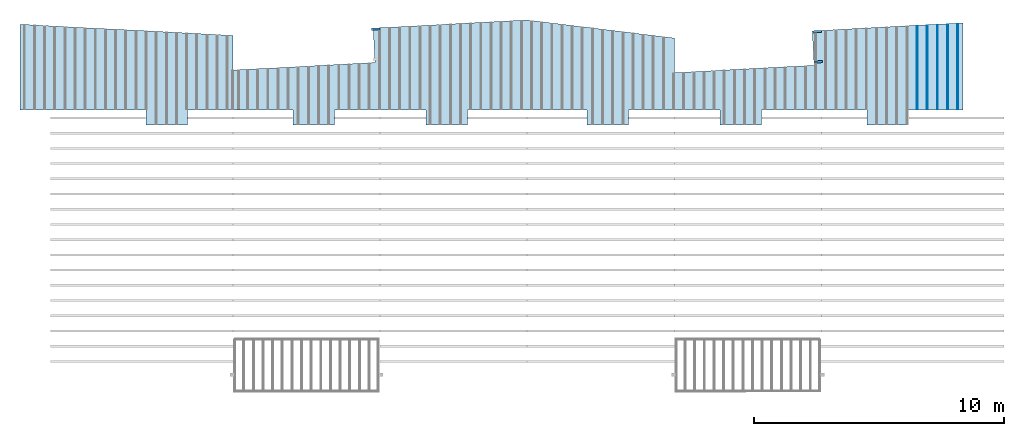
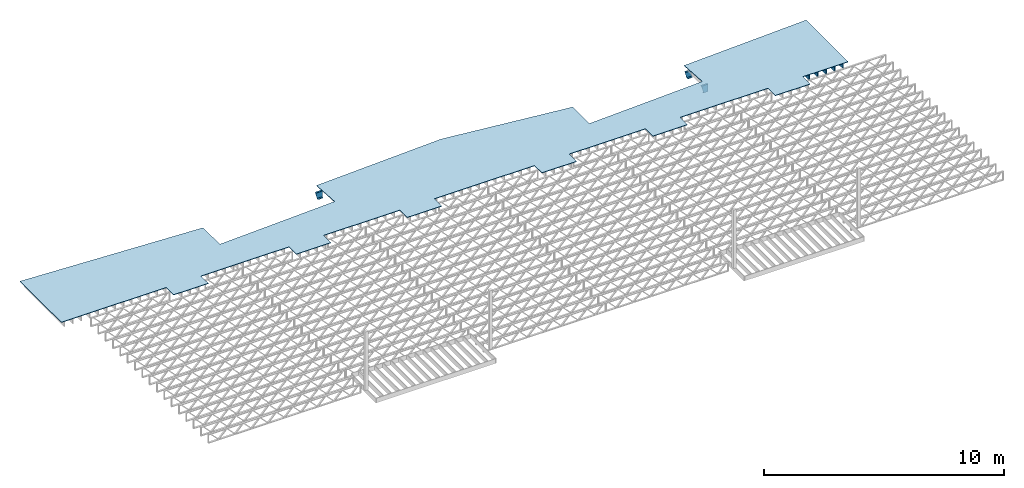
# One storey, part 12 of 12: 8 beams, 1 slab, 1 element without a shape of its own.
"""IFC4 building model written with IfcOpenShell, lengths in feet."""

import ifcopenshell
import ifcopenshell.guid

model = None  # the IFC model being written
_history = None  # IfcOwnerHistory: only IFC2X3 demands one
_inside = {}  # id of a spatial element -> (the spatial element, [elements in it])
_under = {}  # id of a project, library or spatial element -> (it, [spatial elements below it])
_declared = {}  # id of a project -> (the project, [libraries it declares])
_typed = {}  # id of a type object -> (the type object, [elements of that type])
_made_of = {}  # id of a material, layer set ... -> (it, [elements and type objects made of it])


def new_model(schema):
    """Start an empty IFC model of exactly this schema.

    Asked for "IFC4X3", IfcOpenShell would pick the latest addendum, in which some entities
    have other attributes; the version numbers below select the first issue.
    IFC2X3 requires an IfcOwnerHistory on every rooted entity: one is made here for all.
    """
    global model, _history
    if schema == "IFC4X3":
        model = ifcopenshell.file(schema_version=(4, 3, 0, 0))
    else:
        model = ifcopenshell.file(schema=schema)
    _inside.clear()
    _under.clear()
    _declared.clear()
    _typed.clear()
    _made_of.clear()
    _history = None
    if model.schema == "IFC2X3":
        org = make("IfcOrganization", Name="unknown")
        user = make(
            "IfcPersonAndOrganization",
            ThePerson=make("IfcPerson", FamilyName="unknown"),
            TheOrganization=org,
        )
        app = make(
            "IfcApplication",
            ApplicationDeveloper=org,
            Version="unknown",
            ApplicationFullName="unknown",
            ApplicationIdentifier="unknown",
        )
        _history = make(
            "IfcOwnerHistory",
            OwningUser=user,
            OwningApplication=app,
            ChangeAction="ADDED",
            CreationDate=0,
        )
    return model


def make(cls, **values):
    """One entity of the class cls with the attributes given. An attribute that is None is left unset."""
    return model.create_entity(
        cls, **{name: value for name, value in values.items() if value is not None}
    )


def entity(cls, *values):
    """Any entity or typed value of the class cls, its attributes in the order of the schema. None: left unset."""
    e = model.create_entity(cls)
    for i, value in enumerate(values):
        if value is not None:
            e[i] = value
    return e


def rooted(cls, **values):
    """An entity with a GlobalId (a new one), such as an element, a storey or a relation."""
    return make(cls, GlobalId=ifcopenshell.guid.new(), OwnerHistory=_history, **values)


def si_unit(unit_type, name, prefix=None):
    """IfcSIUnit, for example si_unit("LENGTHUNIT", "METRE", prefix="MILLI")."""
    return make("IfcSIUnit", UnitType=unit_type, Prefix=prefix, Name=name)


def converted_unit(unit_type, name, factor, base, dimensions=None, offset=None):
    """IfcConversionBasedUnit, such as the inch: factor (a typed value) times the base unit."""
    return make(
        "IfcConversionBasedUnit"
        if offset is None
        else "IfcConversionBasedUnitWithOffset",
        ConversionOffset=offset,
        Dimensions=None
        if dimensions is None
        else entity("IfcDimensionalExponents", *dimensions),
        UnitType=unit_type,
        Name=name,
        ConversionFactor=make(
            "IfcMeasureWithUnit", ValueComponent=factor, UnitComponent=base
        ),
    )


def derived_unit(unit_type, elements):
    """IfcDerivedUnit: a product of units, each with its exponent."""
    return make(
        "IfcDerivedUnit",
        Elements=[
            make("IfcDerivedUnitElement", Unit=unit, Exponent=power)
            for unit, power in elements
        ],
        UnitType=unit_type,
    )


def assignment(units):
    """IfcUnitAssignment: the units of a project."""
    return None if units is None else make("IfcUnitAssignment", Units=units)


def point(xyz):
    """IfcCartesianPoint."""
    return None if xyz is None else make("IfcCartesianPoint", Coordinates=xyz)


def direction(xyz):
    """IfcDirection."""
    return None if xyz is None else make("IfcDirection", DirectionRatios=xyz)


def frame(location, z_axis=None, x_axis=None):
    """IfcAxis2Placement3D, a coordinate frame: its origin and axes. An axis left out is left unset."""
    return make(
        "IfcAxis2Placement3D",
        Location=point(location),
        Axis=direction(z_axis),
        RefDirection=direction(x_axis),
    )


def frame_2d(location, x_axis=None):
    """IfcAxis2Placement2D, a coordinate frame in the plane: its origin and x axis."""
    return make(
        "IfcAxis2Placement2D", Location=point(location), RefDirection=direction(x_axis)
    )


def origin():
    """The frame at (0, 0, 0) with its axes left unset."""
    return frame((0.0, 0.0, 0.0))


def origin_2d_with_axis():
    """The frame at (0, 0) in the plane with the x axis (1, 0) written out."""
    return frame_2d((0.0, 0.0), x_axis=(1.0, 0.0))


def place(relative_to, where):
    """IfcLocalPlacement: puts the frame where relative to a parent placement (None: the world)."""
    return make(
        "IfcLocalPlacement", PlacementRelTo=relative_to, RelativePlacement=where
    )


def context(
    kind, dimensions, precision=None, world=None, true_north=None, identifier=None
):
    """IfcGeometricRepresentationContext, for example the 3D "Model" context."""
    return make(
        "IfcGeometricRepresentationContext",
        ContextIdentifier=identifier,
        ContextType=kind,
        CoordinateSpaceDimension=dimensions,
        Precision=precision,
        WorldCoordinateSystem=world,
        TrueNorth=true_north,
    )


def subcontext(parent, identifier, kind, view, scale=None):
    """IfcGeometricRepresentationSubContext, for example "Body" below "Model"."""
    return make(
        "IfcGeometricRepresentationSubContext",
        ContextIdentifier=identifier,
        ContextType=kind,
        ParentContext=parent,
        TargetScale=scale,
        TargetView=view,
    )


def project(units=None, contexts=None):
    """IfcProject with its units and contexts."""
    return rooted(
        "IfcProject",
        Name="project",
        RepresentationContexts=contexts,
        UnitsInContext=assignment(units),
    )


def spatial(cls, under=None, at=None, **own):
    """A site, building, storey or space (cls), placed at a placement, below another one or the project."""
    s = rooted(cls, ObjectPlacement=at, **own)
    if under is not None:
        _under.setdefault(under.id(), (under, []))[1].append(s)
    return s


def polyline(points):
    """IfcPolyline through the points."""
    return make("IfcPolyline", Points=[point(p) for p in points])


def circle_curve(where, radius):
    """IfcCircle in the frame where."""
    return make("IfcCircle", Position=where, Radius=radius)


def parameter(value):
    """IfcParameterValue: where a trimmed curve begins or ends, as a parameter of its basis curve."""
    return model.create_entity("IfcParameterValue", value)


def trimmed(basis, trim1, trim2, sense, master):
    """IfcTrimmedCurve: the piece of a basis curve between two trims."""
    return make(
        "IfcTrimmedCurve",
        BasisCurve=basis,
        Trim1=trim1,
        Trim2=trim2,
        SenseAgreement=sense,
        MasterRepresentation=master,
    )


def segment(curve, same_sense, transition):
    """IfcCompositeCurveSegment."""
    return make(
        "IfcCompositeCurveSegment",
        Transition=transition,
        SameSense=same_sense,
        ParentCurve=curve,
    )


def composite_curve(segments, self_intersect=None):
    """IfcCompositeCurve: segments joined end to end."""
    return make("IfcCompositeCurve", Segments=segments, SelfIntersect=self_intersect)


def profile(cls, at=None, kind="AREA", **sizes):
    """A parametric profile (cls). Its sizes go by their IFC names, for example OverallWidth=200.0."""
    return make(cls, ProfileType=kind, Position=at, **sizes)


def rectangle(**sizes):
    """IfcRectangleProfileDef."""
    return profile("IfcRectangleProfileDef", **sizes)


def outline(outer, holes=None, kind="AREA"):
    """IfcArbitraryClosedProfileDef: a profile drawn as a closed curve; with holes, ...WithVoids."""
    if holes is None:
        return make("IfcArbitraryClosedProfileDef", ProfileType=kind, OuterCurve=outer)
    return make(
        "IfcArbitraryProfileDefWithVoids",
        ProfileType=kind,
        OuterCurve=outer,
        InnerCurves=holes,
    )


def extrude(swept, where, along, depth):
    """IfcExtrudedAreaSolid: the profile swept, set in the frame where, extruded along a direction by depth."""
    return make(
        "IfcExtrudedAreaSolid",
        SweptArea=swept,
        Position=where,
        ExtrudedDirection=direction(along),
        Depth=depth,
    )


def clip(a, b, op="DIFFERENCE"):
    """IfcBooleanClippingResult: the solid a cut by the half space b."""
    return make(
        "IfcBooleanClippingResult", Operator=op, FirstOperand=a, SecondOperand=b
    )


def halfspace(plane, agree):
    """IfcHalfSpaceSolid: all space on one side of the plane z = 0 of the frame plane."""
    return make(
        "IfcHalfSpaceSolid",
        BaseSurface=make("IfcPlane", Position=plane),
        AgreementFlag=agree,
    )


def shape(context_of_items, identifier, shape_type, items):
    """IfcShapeRepresentation: the items that make up one representation, for example the "Body"."""
    return make(
        "IfcShapeRepresentation",
        ContextOfItems=context_of_items,
        RepresentationIdentifier=identifier,
        RepresentationType=shape_type,
        Items=items,
    )


def source(mapping_origin, context_of_items, identifier, shape_type, items):
    """IfcRepresentationMap: a shape defined once, which mapped items show again and again."""
    return make(
        "IfcRepresentationMap",
        MappingOrigin=mapping_origin,
        MappedRepresentation=shape(context_of_items, identifier, shape_type, items),
    )


def transform(
    local_origin,
    x_axis=None,
    y_axis=None,
    z_axis=None,
    scale=None,
    scale2=None,
    scale3=None,
    uniform=True,
):
    """IfcCartesianTransformationOperator3D, or its non-uniform kind. x_axis, y_axis, z_axis: its Axis1, 2, 3."""
    if uniform:
        return make(
            "IfcCartesianTransformationOperator3D",
            Axis1=direction(x_axis),
            Axis2=direction(y_axis),
            LocalOrigin=point(local_origin),
            Scale=scale,
            Axis3=direction(z_axis),
        )
    return make(
        "IfcCartesianTransformationOperator3DnonUniform",
        Axis1=direction(x_axis),
        Axis2=direction(y_axis),
        LocalOrigin=point(local_origin),
        Scale=scale,
        Axis3=direction(z_axis),
        Scale2=scale2,
        Scale3=scale3,
    )


def mapped(mapping_source, mapping_target):
    """IfcMappedItem: shows the shape of a source again, moved by a transform."""
    return make(
        "IfcMappedItem", MappingSource=mapping_source, MappingTarget=mapping_target
    )


def material(Name=None, Category=None):
    """IfcMaterial."""
    return make("IfcMaterial", Name=Name, Category=Category)


def layer(
    of_material, thickness, ventilated=None, Name=None, Category=None, Priority=None
):
    """IfcMaterialLayer: one layer of a wall or slab, of a material (None: an air gap)."""
    return make(
        "IfcMaterialLayer",
        Material=of_material,
        LayerThickness=thickness,
        IsVentilated=ventilated,
        Name=Name,
        Category=Category,
        Priority=Priority,
    )


def layer_set(layers, Name=None):
    """IfcMaterialLayerSet."""
    return make("IfcMaterialLayerSet", MaterialLayers=layers, LayerSetName=Name)


def layer_usage(for_layer_set, set_direction, sense, offset, extent=None):
    """IfcMaterialLayerSetUsage: how a layer set lies in its element."""
    return make(
        "IfcMaterialLayerSetUsage",
        ForLayerSet=for_layer_set,
        LayerSetDirection=set_direction,
        DirectionSense=sense,
        OffsetFromReferenceLine=offset,
        ReferenceExtent=extent,
    )


def material_profile(
    of_material, cross_section, Name=None, Category=None, Priority=None
):
    """IfcMaterialProfile: a cross section and its material."""
    return make(
        "IfcMaterialProfile",
        Name=Name,
        Material=of_material,
        Profile=cross_section,
        Priority=Priority,
        Category=Category,
    )


def profile_set(profiles, Name=None, composite=None):
    """IfcMaterialProfileSet."""
    return make(
        "IfcMaterialProfileSet",
        Name=Name,
        MaterialProfiles=profiles,
        CompositeProfile=composite,
    )


def profile_usage(for_profile_set, cardinal=None, extent=None):
    """IfcMaterialProfileSetUsage: how a profile set lies along its element."""
    return make(
        "IfcMaterialProfileSetUsage",
        ForProfileSet=for_profile_set,
        CardinalPoint=cardinal,
        ReferenceExtent=extent,
    )


def made_of(thing, what):
    """Note that an element or type object is made of a material, layer set ...; save() writes the relation."""
    if what is not None:
        _made_of.setdefault(what.id(), (what, []))[1].append(thing)
    return thing


def type_object(cls, material=None, **own):
    """A type object (cls), such as IfcWallType, which elements share."""
    return made_of(rooted(cls, **own), material)


def type_shapes(of_type, sources):
    """Give a type object the sources (RepresentationMaps) that its elements show as mapped items."""
    of_type.RepresentationMaps = sources


def element(
    cls,
    number,
    at=None,
    inside=None,
    cuts=None,
    type_object=None,
    material=None,
    context=None,
    identifier="Body",
    shape_type=None,
    held_by="IfcProductDefinitionShape",
    body=None,
    shapes=None,
    **own,
):
    """One element of the class cls, such as IfcWall. Its Tag is "e" and its number.

    at: its placement. inside: the storey or other place that contains it. cuts: it is an
    opening in that element (IfcRelVoidsElement). A single representation is given by context,
    identifier, shape_type and body (its items); several are given by shapes. held_by: the class
    of the entity that holds the representations. save() writes the other relations.
    """
    e = rooted(cls, Tag="e%d" % number, ObjectPlacement=at, **own)
    if body is not None:
        shapes = [shape(context, identifier, shape_type, body)]
    if shapes is not None:
        e.Representation = make(held_by, Representations=shapes)
    if inside is not None:
        _inside.setdefault(inside.id(), (inside, []))[1].append(e)
    if cuts is not None:
        rooted(
            "IfcRelVoidsElement", RelatingBuildingElement=cuts, RelatedOpeningElement=e
        )
    if type_object is not None:
        _typed.setdefault(type_object.id(), (type_object, []))[1].append(e)
    return made_of(e, material)


def aggregate(whole, parts):
    """IfcRelAggregates: a whole, such as a stair, and the parts it consists of."""
    return rooted("IfcRelAggregates", RelatingObject=whole, RelatedObjects=parts)


def save(model, path):
    """Write the relations noted so far, then the file.

    IfcRelAggregates (storeys below a building ...), IfcRelContainedInSpatialStructure (elements
    in a storey), IfcRelDefinesByType, IfcRelAssociatesMaterial and IfcRelDeclares: one each for
    every whole, place, type object, material and project.
    """
    for whole, parts in _under.values():
        aggregate(whole, parts)
    for where, things in _inside.values():
        rooted(
            "IfcRelContainedInSpatialStructure",
            RelatedElements=things,
            RelatingStructure=where,
        )
    for kind, things in _typed.values():
        rooted("IfcRelDefinesByType", RelatedObjects=things, RelatingType=kind)
    for what, things in _made_of.values():
        rooted("IfcRelAssociatesMaterial", RelatedObjects=things, RelatingMaterial=what)
    for by, libraries in _declared.values():
        rooted("IfcRelDeclares", RelatingContext=by, RelatedDefinitions=libraries)
    model.write(path)


model = new_model("IFC4")

# Units and contexts
model_context = context("Model", 3, precision=0.0001, world=origin(), true_north=direction((6.12303176911189e-17, 1.0)))
body_context = subcontext(model_context, "Body", "Model", "MODEL_VIEW")
ifc_project = project(units=[converted_unit("LENGTHUNIT", "FOOT", entity("IfcRatioMeasure", 0.3048), si_unit("LENGTHUNIT", "METRE"), dimensions=[1, 0, 0, 0, 0, 0, 0]), converted_unit("AREAUNIT", "SQUARE FOOT", entity("IfcRatioMeasure", 0.09290304), si_unit("AREAUNIT", "SQUARE_METRE"), dimensions=[2, 0, 0, 0, 0, 0, 0]), converted_unit("VOLUMEUNIT", "CUBIC FOOT", entity("IfcRatioMeasure", 0.028316846592), si_unit("VOLUMEUNIT", "CUBIC_METRE"), dimensions=[3, 0, 0, 0, 0, 0, 0]), converted_unit("PLANEANGLEUNIT", "DEGREE", entity("IfcRatioMeasure", 0.0174532925199433), si_unit("PLANEANGLEUNIT", "RADIAN"), dimensions=[0, 0, 0, 0, 0, 0, 0]), si_unit("MASSUNIT", "GRAM", prefix="KILO"), derived_unit("MASSDENSITYUNIT", [(si_unit("MASSUNIT", "GRAM", prefix="KILO"), 1), (si_unit("LENGTHUNIT", "METRE"), -3)]), derived_unit("MOMENTOFINERTIAUNIT", [(si_unit("LENGTHUNIT", "METRE"), 4)]), si_unit("TIMEUNIT", "SECOND"), si_unit("FREQUENCYUNIT", "HERTZ"), si_unit("THERMODYNAMICTEMPERATUREUNIT", "DEGREE_CELSIUS"), derived_unit("THERMALTRANSMITTANCEUNIT", [(si_unit("MASSUNIT", "GRAM", prefix="KILO"), 1), (si_unit("THERMODYNAMICTEMPERATUREUNIT", "KELVIN"), -1), (si_unit("TIMEUNIT", "SECOND"), -3)]), derived_unit("VOLUMETRICFLOWRATEUNIT", [(si_unit("LENGTHUNIT", "METRE"), 3), (si_unit("TIMEUNIT", "SECOND"), -1)]), si_unit("ELECTRICCURRENTUNIT", "AMPERE"), si_unit("ELECTRICVOLTAGEUNIT", "VOLT"), si_unit("POWERUNIT", "WATT"), si_unit("FORCEUNIT", "NEWTON"), si_unit("ILLUMINANCEUNIT", "LUX"), si_unit("LUMINOUSFLUXUNIT", "LUMEN"), si_unit("LUMINOUSINTENSITYUNIT", "CANDELA"), derived_unit("USERDEFINED", [(si_unit("MASSUNIT", "GRAM", prefix="KILO"), -1), (si_unit("LENGTHUNIT", "METRE"), -2), (si_unit("TIMEUNIT", "SECOND"), 3), (si_unit("LUMINOUSFLUXUNIT", "LUMEN"), 1)]), derived_unit("LINEARVELOCITYUNIT", [(si_unit("LENGTHUNIT", "METRE"), 1), (si_unit("TIMEUNIT", "SECOND"), -1)]), si_unit("PRESSUREUNIT", "PASCAL"), derived_unit("USERDEFINED", [(si_unit("LENGTHUNIT", "METRE"), -2), (si_unit("MASSUNIT", "GRAM", prefix="KILO"), 1), (si_unit("TIMEUNIT", "SECOND"), -2)]), derived_unit("LINEARFORCEUNIT", [(si_unit("MASSUNIT", "GRAM", prefix="KILO"), 1), (si_unit("LENGTHUNIT", "METRE"), 1), (si_unit("TIMEUNIT", "SECOND"), -2), (si_unit("LENGTHUNIT", "METRE"), -1)]), derived_unit("PLANARFORCEUNIT", [(si_unit("MASSUNIT", "GRAM", prefix="KILO"), 1), (si_unit("LENGTHUNIT", "METRE"), 1), (si_unit("TIMEUNIT", "SECOND"), -2), (si_unit("LENGTHUNIT", "METRE"), -2)])], contexts=[model_context])

# Site, building, storey
site_placement = place(None, origin())
site = spatial("IfcSite", under=ifc_project, at=site_placement, CompositionType="ELEMENT")
building_placement = place(site_placement, origin())
building = spatial("IfcBuilding", under=site, at=building_placement, CompositionType="ELEMENT")
storey_placement = place(building_placement, frame((0.0, 0.0, 21.46875)))
storey = spatial("IfcBuildingStorey", under=building, at=storey_placement, Name="3RD FLOOR", CompositionType="ELEMENT", Elevation=21.46875)

# Beams
ifc_material_1 = material(Name="STEEL C CHANNEL - HDG - SEE STRUCT", Category="Materials")
ifc_material_profile_1 = material_profile(ifc_material_1, outline(composite_curve([segment(polyline([(-0.625000000000096, -0.136458333333336), (0.625000000000011, -0.136458333333336)]), True, "CONTINUOUS"), segment(polyline([(0.625000000000011, -0.136458333333336), (0.625000000000011, 0.14687499999997)]), True, "CONTINUOUS"), segment(trimmed(circle_curve(frame_2d((0.624999999999954, 0.0927083333333472), x_axis=(0.0, 1.0)), 0.054166666666607), [parameter(0.0)], [parameter(90.0000000000565)], True, "PARAMETER"), True, "CONTINUOUS"), segment(polyline([(0.570833333333347, 0.0927083333333473), (0.539816380436459, -0.1031250000001)]), True, "CONTINUOUS"), segment(polyline([(0.539816380436459, -0.103124999999986), (-0.539816380436541, -0.103124999999985)]), True, "CONTINUOUS"), segment(polyline([(-0.539816380436431, -0.103124999999985), (-0.570833333333319, 0.0927083333333486)]), True, "CONTINUOUS"), segment(trimmed(circle_curve(frame_2d((-0.624999999999922, 0.0927083333333487), x_axis=(1.0, 0.0)), 0.0541666666665973), [parameter(0.0)], [parameter(90.0000000001767)], True, "PARAMETER"), True, "CONTINUOUS"), segment(polyline([(-0.624999999999989, 0.14687499999997), (-0.624999999999986, -0.136458333333336)]), True, "CONTINUOUS")], self_intersect=False)), Name="C15x33.9, TYP. STRINGER")
ifc_profile_set_1 = profile_set([ifc_material_profile_1], Name="C15x33.9, TYP. STRINGER")
ifc_profile_usage_1 = profile_usage(ifc_profile_set_1, cardinal=8)
beam_type_1 = type_object("IfcBeamType", Name="C-Channel:C15x33.9, TYP. STRINGER", PredefinedType="BEAM", material=ifc_profile_set_1)
shared_shape_1 = source(origin(), body_context, "Body", "Clipping", [
    clip(extrude(outline(composite_curve([segment(polyline([(-0.625000000000096, -0.136458333333336), (0.625000000000011, -0.136458333333336)]), True, "CONTINUOUS"), segment(polyline([(0.625000000000011, -0.136458333333336), (0.625000000000011, 0.14687499999997)]), True, "CONTINUOUS"), segment(trimmed(circle_curve(frame_2d((0.624999999999954, 0.0927083333333472), x_axis=(0.0, 1.0)), 0.054166666666607), [parameter(0.0)], [parameter(90.0000000000565)], True, "PARAMETER"), True, "CONTINUOUS"), segment(polyline([(0.570833333333347, 0.0927083333333473), (0.539816380436459, -0.1031250000001)]), True, "CONTINUOUS"), segment(polyline([(0.539816380436459, -0.103124999999986), (-0.539816380436541, -0.103124999999985)]), True, "CONTINUOUS"), segment(polyline([(-0.539816380436431, -0.103124999999985), (-0.570833333333319, 0.0927083333333486)]), True, "CONTINUOUS"), segment(trimmed(circle_curve(frame_2d((-0.624999999999922, 0.0927083333333487), x_axis=(1.0, 0.0)), 0.0541666666665973), [parameter(0.0)], [parameter(90.0000000001767)], True, "PARAMETER"), True, "CONTINUOUS"), segment(polyline([(-0.624999999999989, 0.14687499999997), (-0.624999999999986, -0.136458333333336)]), True, "CONTINUOUS")], self_intersect=False)), frame((-223.549097244249, 969.525938404838, 19.645833333333), z_axis=(0.998629534754577, 0.0523359562428793, 0.0), x_axis=(0.0, 0.0, 1.0)), (0.0, 0.0, 1.0), 1.14955046056795), halfspace(frame((-223.263210744256, 966.417619809988, 19.8353538978054), z_axis=(-0.961136240283351, -0.050371015941545, -0.271440395606476), x_axis=(0.271068395978093, 0.0142060926670286, -0.962455251756153)), False)),
])
type_shapes(beam_type_1, [shared_shape_1])
beam_1_placement = place(storey_placement, frame((0.0, 0.0, -21.46875)))
element("IfcBeam", 1, at=beam_1_placement, inside=storey, type_object=beam_type_1, material=ifc_profile_usage_1, Name="C-Channel:C15x33.9, TYP. STRINGER", ObjectType="C-Channel:C15x33.9, TYP. STRINGER", PredefinedType="BEAM", context=body_context, shape_type="MappedRepresentation", body=[
    mapped(shared_shape_1, transform((0.0, 0.0, 0.0), scale=1.0)),
])
ifc_profile_usage_2 = profile_usage(ifc_profile_set_1, cardinal=8)
beam_type_2 = type_object("IfcBeamType", Name="C-Channel:C15x33.9, TYP. STRINGER", PredefinedType="BEAM", material=ifc_profile_set_1)
shared_shape_2 = source(origin(), body_context, "Body", "Clipping", [
    clip(extrude(outline(composite_curve([segment(polyline([(-0.625000000000092, -0.136458333333449), (0.625000000000018, -0.136458333333449)]), True, "CONTINUOUS"), segment(polyline([(0.625000000000014, -0.136458333333449), (0.625000000000018, 0.146874999999857)]), True, "CONTINUOUS"), segment(trimmed(circle_curve(frame_2d((0.624999999999957, 0.0927083333332337), x_axis=(0.0, 1.0)), 0.054166666666607), [parameter(0.0)], [parameter(90.0000000000565)], True, "PARAMETER"), True, "CONTINUOUS"), segment(polyline([(0.570833333333351, 0.0927083333332337), (0.539816380436459, -0.103125000000213)]), True, "CONTINUOUS"), segment(polyline([(0.539816380436463, -0.1031250000001), (-0.539816380436538, -0.103125000000098)]), True, "CONTINUOUS"), segment(polyline([(-0.539816380436427, -0.103125000000098), (-0.570833333333315, 0.0927083333332351)]), True, "CONTINUOUS"), segment(trimmed(circle_curve(frame_2d((-0.624999999999918, 0.0927083333332352), x_axis=(1.0, 0.0)), 0.0541666666665973), [parameter(0.0)], [parameter(90.0000000001767)], True, "PARAMETER"), True, "CONTINUOUS"), segment(polyline([(-0.624999999999986, 0.146874999999857), (-0.624999999999982, -0.136458333333449)]), True, "CONTINUOUS")], self_intersect=False)), frame((-165.549097244249, 969.178537692993, 19.645833333333), z_axis=(0.998629534754577, 0.0523359562428793, 0.0), x_axis=(0.0, 0.0, 1.0)), (0.0, 0.0, 1.0), 1.14955046056795), halfspace(frame((-165.263210744256, 966.070219098144, 19.8353538978054), z_axis=(-0.961136240283351, -0.050371015941545, -0.271440395606476), x_axis=(0.271068395978093, 0.0142060926670286, -0.962455251756153)), False)),
])
type_shapes(beam_type_2, [shared_shape_2])
beam_2_placement = place(storey_placement, frame((0.0, 0.0, -21.46875)))
element("IfcBeam", 2, at=beam_2_placement, inside=storey, type_object=beam_type_2, material=ifc_profile_usage_2, Name="C-Channel:C15x33.9, TYP. STRINGER", ObjectType="C-Channel:C15x33.9, TYP. STRINGER", PredefinedType="BEAM", context=body_context, shape_type="MappedRepresentation", body=[
    mapped(shared_shape_2, transform((0.0, 0.0, 0.0), scale=1.0)),
])
ifc_profile_usage_3 = profile_usage(ifc_profile_set_1, cardinal=8)
beam_type_3 = type_object("IfcBeamType", Name="C-Channel:C15x33.9, TYP. STRINGER", PredefinedType="BEAM", material=ifc_profile_set_1)
shared_shape_3 = source(origin(), body_context, "Body", "Clipping", [
    clip(extrude(outline(composite_curve([segment(polyline([(-0.146875000000084, -0.624999999999996), (0.136458333333335, -0.624999999999996)]), True, "CONTINUOUS"), segment(polyline([(0.13645833333322, -0.625000000000028), (0.136458333333335, 0.625000000000004)]), True, "CONTINUOUS"), segment(polyline([(0.136458333333335, 0.625), (-0.146874999999971, 0.625000000000004)]), True, "CONTINUOUS"), segment(trimmed(circle_curve(frame_2d((-0.092708333333348, 0.62499999999994), x_axis=(-1.0, 0.0)), 0.0541666666666108), [parameter(0.0)], [parameter(90.0000000000677)], True, "PARAMETER"), True, "CONTINUOUS"), segment(polyline([(-0.0927083333334615, 0.570833333333333), (0.103124999999984, 0.539816380436445)]), True, "CONTINUOUS"), segment(polyline([(0.10312499999987, 0.539816380436445), (0.103124999999984, -0.539816380436477)]), True, "CONTINUOUS"), segment(polyline([(0.103124999999984, -0.539816380436445), (-0.092708333333348, -0.570833333333333)]), True, "CONTINUOUS"), segment(trimmed(circle_curve(frame_2d((-0.092708333333348, -0.624999999999947), x_axis=(0.0, 1.0)), 0.0541666666666185), [parameter(0.0)], [parameter(90.0000000000715)], True, "PARAMETER"), True, "CONTINUOUS")], self_intersect=False)), frame((-165.340952784941, 965.206904814139, 19.6458333333331), z_axis=(0.998629534754578, 0.0523359562428584, 0.0), x_axis=(0.0523359562428584, -0.998629534754578, 0.0)), (0.0, 0.0, 1.0), 1.08631719611224), halfspace(frame((-165.263210744256, 966.070219098144, 19.8353538978054), z_axis=(-0.961136240283351, -0.050371015941545, -0.271440395606476), x_axis=(0.271068395978093, 0.0142060926670286, -0.962455251756153)), False)),
])
type_shapes(beam_type_3, [shared_shape_3])
beam_3_placement = place(storey_placement, frame((0.0, 0.0, -21.46875)))
element("IfcBeam", 3, at=beam_3_placement, inside=storey, type_object=beam_type_3, material=ifc_profile_usage_3, Name="C-Channel:C15x33.9, TYP. STRINGER", ObjectType="C-Channel:C15x33.9, TYP. STRINGER", PredefinedType="BEAM", context=body_context, shape_type="MappedRepresentation", body=[
    mapped(shared_shape_3, transform((0.0, 0.0, 0.0), scale=1.0)),
])

# Assembly, beams
assembly_placement = place(storey_placement, origin())
assembly = element("IfcElementAssembly", 4, at=assembly_placement, inside=storey, Name="Structural Beam System:Structural Framing System", ObjectType="Structural Beam System:Structural Framing System", AssemblyPlace="NOTDEFINED", PredefinedType="BEAM_GRID")
ifc_material_2 = material(Category="Materials")
ifc_material_profile_2 = material_profile(ifc_material_2, rectangle(XDim=0.9375, YDim=0.125000000000011, at=origin_2d_with_axis()))
ifc_profile_set_2 = profile_set([ifc_material_profile_2])
ifc_profile_usage_4 = profile_usage(ifc_profile_set_2, cardinal=8)
beam_type_4 = type_object("IfcBeamType", PredefinedType="BEAM", material=ifc_profile_set_2)
shared_shape_4 = source(origin(), body_context, "Body", "SweptSolid", [
    extrude(rectangle(XDim=0.9375, YDim=0.125000000000011, at=origin_2d_with_axis()), frame((-5.44069959830534, 0.0, 0.0), z_axis=(1.0, 0.0, 0.0), x_axis=(0.0, 0.0, -1.0)), (0.0, 0.0, 1.0), 10.8813991966107),
])
type_shapes(beam_type_4, [shared_shape_4])
beam_4_placement = place(assembly_placement, frame((-151.810956052701, 964.469297547199, -0.729166666666714), z_axis=(0.0, 0.0, 1.0), x_axis=(0.0, 1.0, 0.0)))
beam_4 = element("IfcBeam", 5, at=beam_4_placement, type_object=beam_type_4, material=ifc_profile_usage_4, PredefinedType="BEAM", context=body_context, shape_type="MappedRepresentation", body=[
    mapped(shared_shape_4, transform((0.0, 0.0, 0.0), scale=1.0)),
])
ifc_profile_usage_5 = profile_usage(ifc_profile_set_2, cardinal=8)
beam_type_5 = type_object("IfcBeamType", PredefinedType="BEAM", material=ifc_profile_set_2)
shared_shape_5 = source(origin(), body_context, "Body", "SweptSolid", [
    extrude(rectangle(XDim=0.9375, YDim=0.125000000000011, at=origin_2d_with_axis()), frame((-5.47563795032625, 0.0, 0.0), z_axis=(1.0, 0.0, 0.0), x_axis=(0.0, 0.0, -1.0)), (0.0, 0.0, 1.0), 10.9512759006525),
])
type_shapes(beam_type_5, [shared_shape_5])
beam_5_placement = place(assembly_placement, frame((-150.477622719368, 964.504236234223, -0.729166666666714), z_axis=(0.0, 0.0, 1.0), x_axis=(0.0, 1.0, 0.0)))
beam_5 = element("IfcBeam", 6, at=beam_5_placement, type_object=beam_type_5, material=ifc_profile_usage_5, PredefinedType="BEAM", context=body_context, shape_type="MappedRepresentation", body=[
    mapped(shared_shape_5, transform((0.0, 0.0, 0.0), scale=1.0)),
])
ifc_profile_usage_6 = profile_usage(ifc_profile_set_2, cardinal=8)
beam_type_6 = type_object("IfcBeamType", PredefinedType="BEAM", material=ifc_profile_set_2)
shared_shape_6 = source(origin(), body_context, "Body", "SweptSolid", [
    extrude(rectangle(XDim=0.9375, YDim=0.125000000000011, at=origin_2d_with_axis()), frame((-5.51057630234703, 0.0, 0.0), z_axis=(1.0, 0.0, 0.0), x_axis=(0.0, 0.0, -1.0)), (0.0, 0.0, 1.0), 11.0211526046941),
])
type_shapes(beam_type_6, [shared_shape_6])
beam_6_placement = place(assembly_placement, frame((-149.144289386034, 964.539174921246, -0.729166666666714), z_axis=(0.0, 0.0, 1.0), x_axis=(0.0, 1.0, 0.0)))
beam_6 = element("IfcBeam", 7, at=beam_6_placement, type_object=beam_type_6, material=ifc_profile_usage_6, PredefinedType="BEAM", context=body_context, shape_type="MappedRepresentation", body=[
    mapped(shared_shape_6, transform((0.0, 0.0, 0.0), scale=1.0)),
])
ifc_profile_usage_7 = profile_usage(ifc_profile_set_2, cardinal=8)
beam_type_7 = type_object("IfcBeamType", PredefinedType="BEAM", material=ifc_profile_set_2)
shared_shape_7 = source(origin(), body_context, "Body", "SweptSolid", [
    extrude(rectangle(XDim=0.9375, YDim=0.125000000000011, at=origin_2d_with_axis()), frame((-5.54551465436788, 0.0, 0.0), z_axis=(1.0, 0.0, 0.0), x_axis=(0.0, 0.0, -1.0)), (0.0, 0.0, 1.0), 11.0910293087358),
])
type_shapes(beam_type_7, [shared_shape_7])
beam_7_placement = place(assembly_placement, frame((-147.810956052701, 964.574113608269, -0.729166666666714), z_axis=(0.0, 0.0, 1.0), x_axis=(0.0, 1.0, 0.0)))
beam_7 = element("IfcBeam", 8, at=beam_7_placement, type_object=beam_type_7, material=ifc_profile_usage_7, PredefinedType="BEAM", context=body_context, shape_type="MappedRepresentation", body=[
    mapped(shared_shape_7, transform((0.0, 0.0, 0.0), scale=1.0)),
])
ifc_profile_usage_8 = profile_usage(ifc_profile_set_2, cardinal=8)
beam_type_8 = type_object("IfcBeamType", PredefinedType="BEAM", material=ifc_profile_set_2)
shared_shape_8 = source(origin(), body_context, "Body", "SweptSolid", [
    extrude(rectangle(XDim=0.9375, YDim=0.125000000000011, at=origin_2d_with_axis()), frame((-5.58045300638878, 0.0, 0.0), z_axis=(1.0, 0.0, 0.0), x_axis=(0.0, 0.0, -1.0)), (0.0, 0.0, 1.0), 11.1609060127776),
])
type_shapes(beam_type_8, [shared_shape_8])
beam_8_placement = place(assembly_placement, frame((-146.477622719368, 964.609052295292, -0.729166666666714), z_axis=(0.0, 0.0, 1.0), x_axis=(0.0, 1.0, 0.0)))
beam_8 = element("IfcBeam", 9, at=beam_8_placement, type_object=beam_type_8, material=ifc_profile_usage_8, PredefinedType="BEAM", context=body_context, shape_type="MappedRepresentation", body=[
    mapped(shared_shape_8, transform((0.0, 0.0, 0.0), scale=1.0)),
])
aggregate(assembly, [beam_4, beam_5, beam_6, beam_7, beam_8])

# Slab
ifc_material_3 = material(Name="COMPOSITE DECKING", Category="Materials")
ifc_layer = layer(ifc_material_3, 0.0833333333333333, Name="COMPOSITE DECKING", Category="Materials")
ifc_layer_set = layer_set([ifc_layer], Name="Floor:floor")
ifc_layer_usage = layer_usage(ifc_layer_set, "AXIS3", "POSITIVE", 0.0)
slab_type = type_object("IfcSlabType", Name="Floor:floor", PredefinedType="FLOOR", material=ifc_layer_set)
slab_placement = place(storey_placement, origin())
element("IfcSlab", 10, at=slab_placement, inside=storey, type_object=slab_type, material=ifc_layer_usage, Name="Floor:floor", ObjectType="Floor:floor", PredefinedType="FLOOR", context=body_context, shape_type="SweptSolid", body=[
    extrude(outline(polyline([(-1.98033034843547, -66.0562902884965), (9.29277395593613, -66.0562902884965), (7.82540166860213, -38.0571591020844), (3.27750707097368, -38.0571591020844), (4.25506133558929, -19.404312559236), (8.79050401399854, -19.6420050380767), (9.85183830875235, 0.609459711505053), (7.47800339388004, 19.9427936210479), (2.93010416499521, 19.9427936210479), (3.8925170201527, 38.306724860383), (8.42797016507154, 38.0692375047629), (9.46687868842082, 57.8927930448347), (-1.98032855120073, 57.8927930448347), (-1.98033034974446, 50.7344599971799), (-3.98032986870351, 50.7344594946763), (-3.98032986870351, 45.276126349964), (-1.98032707903019, 45.276126349964), (-1.98033056383395, 31.4063327962017), (-3.98032986870351, 31.4063332987042), (-3.98032986870351, 25.9427925098845), (-1.98032938330266, 25.9427929988073), (-1.98032644976661, 13.9427933654327), (-3.98032986870373, 13.9427933654327), (-3.98032986870373, 8.48445954404463), (-1.98032660793228, 8.48445954404463), (-1.98033053349741, -7.26554037027961), (-3.98032986870362, -7.26553987179531), (-3.98032986870362, -12.7238741868868), (-1.98032938330198, -12.7238736979644), (-1.98032644976877, -24.7238710863774), (-3.98032986870373, -24.7238710863774), (-3.98032986870373, -30.1874138455924), (-1.98032939924929, -30.1874133430885), (-1.98032591443757, -44.0572053751534), (-3.98032986870373, -44.057205877658), (-3.98032986870373, -49.5207497003005), (-1.98033034843547, -49.5207502028041), (-1.98033034843547, -66.0562902884965)])), frame((-203.680953530366, 960.883931418021, -0.177083333333229), z_axis=(0.0, 0.0, -1.0), x_axis=(0.0, 1.0, 0.0)), (0.0, 0.0, 1.0), 0.0833333333333321),
])

save(model, "model.ifc")
